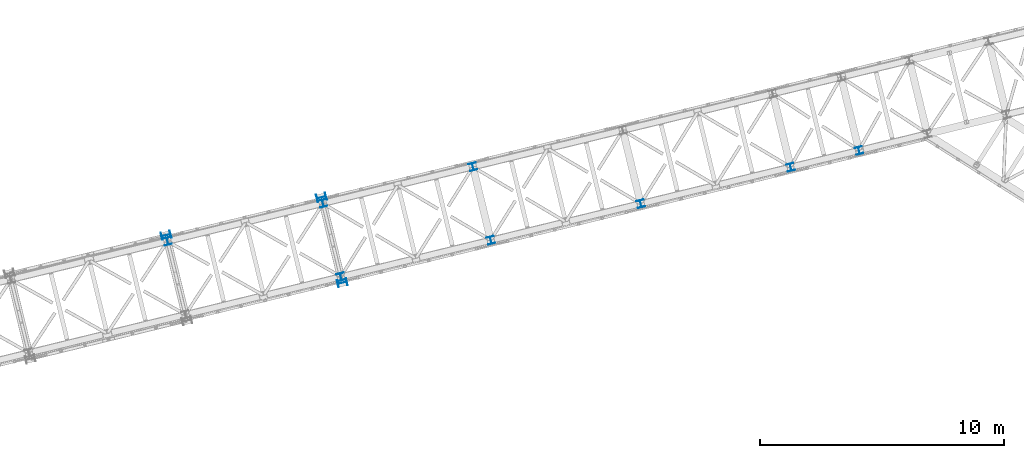
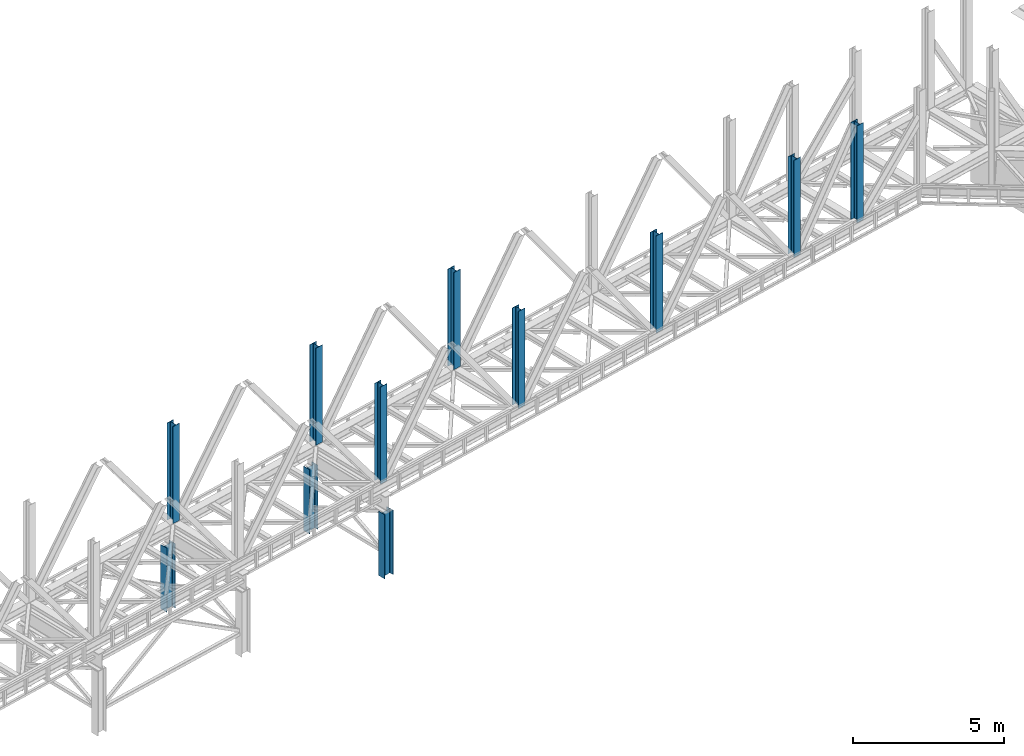
# One storey, part 2 of 93: 11 columns.
"""IFC4 building model written with IfcOpenShell, lengths in millimetres."""

import ifcopenshell
import ifcopenshell.guid

model = None  # the IFC model being written
_history = None  # IfcOwnerHistory: only IFC2X3 demands one
_inside = {}  # id of a spatial element -> (the spatial element, [elements in it])
_under = {}  # id of a project, library or spatial element -> (it, [spatial elements below it])
_declared = {}  # id of a project -> (the project, [libraries it declares])
_typed = {}  # id of a type object -> (the type object, [elements of that type])
_made_of = {}  # id of a material, layer set ... -> (it, [elements and type objects made of it])


def new_model(schema):
    """Start an empty IFC model of exactly this schema.

    Asked for "IFC4X3", IfcOpenShell would pick the latest addendum, in which some entities
    have other attributes; the version numbers below select the first issue.
    IFC2X3 requires an IfcOwnerHistory on every rooted entity: one is made here for all.
    """
    global model, _history
    if schema == "IFC4X3":
        model = ifcopenshell.file(schema_version=(4, 3, 0, 0))
    else:
        model = ifcopenshell.file(schema=schema)
    _inside.clear()
    _under.clear()
    _declared.clear()
    _typed.clear()
    _made_of.clear()
    _history = None
    if model.schema == "IFC2X3":
        org = make("IfcOrganization", Name="unknown")
        user = make(
            "IfcPersonAndOrganization",
            ThePerson=make("IfcPerson", FamilyName="unknown"),
            TheOrganization=org,
        )
        app = make(
            "IfcApplication",
            ApplicationDeveloper=org,
            Version="unknown",
            ApplicationFullName="unknown",
            ApplicationIdentifier="unknown",
        )
        _history = make(
            "IfcOwnerHistory",
            OwningUser=user,
            OwningApplication=app,
            ChangeAction="ADDED",
            CreationDate=0,
        )
    return model


def make(cls, **values):
    """One entity of the class cls with the attributes given. An attribute that is None is left unset."""
    return model.create_entity(
        cls, **{name: value for name, value in values.items() if value is not None}
    )


def entity(cls, *values):
    """Any entity or typed value of the class cls, its attributes in the order of the schema. None: left unset."""
    e = model.create_entity(cls)
    for i, value in enumerate(values):
        if value is not None:
            e[i] = value
    return e


def rooted(cls, **values):
    """An entity with a GlobalId (a new one), such as an element, a storey or a relation."""
    return make(cls, GlobalId=ifcopenshell.guid.new(), OwnerHistory=_history, **values)


def si_unit(unit_type, name, prefix=None):
    """IfcSIUnit, for example si_unit("LENGTHUNIT", "METRE", prefix="MILLI")."""
    return make("IfcSIUnit", UnitType=unit_type, Prefix=prefix, Name=name)


def converted_unit(unit_type, name, factor, base, dimensions=None, offset=None):
    """IfcConversionBasedUnit, such as the inch: factor (a typed value) times the base unit."""
    return make(
        "IfcConversionBasedUnit"
        if offset is None
        else "IfcConversionBasedUnitWithOffset",
        ConversionOffset=offset,
        Dimensions=None
        if dimensions is None
        else entity("IfcDimensionalExponents", *dimensions),
        UnitType=unit_type,
        Name=name,
        ConversionFactor=make(
            "IfcMeasureWithUnit", ValueComponent=factor, UnitComponent=base
        ),
    )


def derived_unit(unit_type, elements):
    """IfcDerivedUnit: a product of units, each with its exponent."""
    return make(
        "IfcDerivedUnit",
        Elements=[
            make("IfcDerivedUnitElement", Unit=unit, Exponent=power)
            for unit, power in elements
        ],
        UnitType=unit_type,
    )


def assignment(units):
    """IfcUnitAssignment: the units of a project."""
    return None if units is None else make("IfcUnitAssignment", Units=units)


def point(xyz):
    """IfcCartesianPoint."""
    return None if xyz is None else make("IfcCartesianPoint", Coordinates=xyz)


def direction(xyz):
    """IfcDirection."""
    return None if xyz is None else make("IfcDirection", DirectionRatios=xyz)


def frame(location, z_axis=None, x_axis=None):
    """IfcAxis2Placement3D, a coordinate frame: its origin and axes. An axis left out is left unset."""
    return make(
        "IfcAxis2Placement3D",
        Location=point(location),
        Axis=direction(z_axis),
        RefDirection=direction(x_axis),
    )


def origin():
    """The frame at (0, 0, 0) with its axes left unset."""
    return frame((0.0, 0.0, 0.0))


def place(relative_to, where):
    """IfcLocalPlacement: puts the frame where relative to a parent placement (None: the world)."""
    return make(
        "IfcLocalPlacement", PlacementRelTo=relative_to, RelativePlacement=where
    )


def context(
    kind, dimensions, precision=None, world=None, true_north=None, identifier=None
):
    """IfcGeometricRepresentationContext, for example the 3D "Model" context."""
    return make(
        "IfcGeometricRepresentationContext",
        ContextIdentifier=identifier,
        ContextType=kind,
        CoordinateSpaceDimension=dimensions,
        Precision=precision,
        WorldCoordinateSystem=world,
        TrueNorth=true_north,
    )


def subcontext(parent, identifier, kind, view, scale=None):
    """IfcGeometricRepresentationSubContext, for example "Body" below "Model"."""
    return make(
        "IfcGeometricRepresentationSubContext",
        ContextIdentifier=identifier,
        ContextType=kind,
        ParentContext=parent,
        TargetScale=scale,
        TargetView=view,
    )


def project(units=None, contexts=None):
    """IfcProject with its units and contexts."""
    return rooted(
        "IfcProject",
        Name="project",
        RepresentationContexts=contexts,
        UnitsInContext=assignment(units),
    )


def spatial(cls, under=None, at=None, **own):
    """A site, building, storey or space (cls), placed at a placement, below another one or the project."""
    s = rooted(cls, ObjectPlacement=at, **own)
    if under is not None:
        _under.setdefault(under.id(), (under, []))[1].append(s)
    return s


def point_list(points):
    """IfcCartesianPointList2D or 3D."""
    cls = (
        "IfcCartesianPointList2D" if len(points[0]) == 2 else "IfcCartesianPointList3D"
    )
    return make(cls, CoordList=points)


def indexed_curve(points, segments=None, self_intersect=None):
    """IfcIndexedPolyCurve: lines and arcs through numbered points (the first is 1)."""
    return make(
        "IfcIndexedPolyCurve",
        Points=point_list(points),
        Segments=segments,
        SelfIntersect=self_intersect,
    )


def outline(outer, holes=None, kind="AREA"):
    """IfcArbitraryClosedProfileDef: a profile drawn as a closed curve; with holes, ...WithVoids."""
    if holes is None:
        return make("IfcArbitraryClosedProfileDef", ProfileType=kind, OuterCurve=outer)
    return make(
        "IfcArbitraryProfileDefWithVoids",
        ProfileType=kind,
        OuterCurve=outer,
        InnerCurves=holes,
    )


def extrude(swept, where, along, depth):
    """IfcExtrudedAreaSolid: the profile swept, set in the frame where, extruded along a direction by depth."""
    return make(
        "IfcExtrudedAreaSolid",
        SweptArea=swept,
        Position=where,
        ExtrudedDirection=direction(along),
        Depth=depth,
    )


def shape(context_of_items, identifier, shape_type, items):
    """IfcShapeRepresentation: the items that make up one representation, for example the "Body"."""
    return make(
        "IfcShapeRepresentation",
        ContextOfItems=context_of_items,
        RepresentationIdentifier=identifier,
        RepresentationType=shape_type,
        Items=items,
    )


def made_of(thing, what):
    """Note that an element or type object is made of a material, layer set ...; save() writes the relation."""
    if what is not None:
        _made_of.setdefault(what.id(), (what, []))[1].append(thing)
    return thing


def type_object(cls, material=None, **own):
    """A type object (cls), such as IfcWallType, which elements share."""
    return made_of(rooted(cls, **own), material)


def element(
    cls,
    number,
    at=None,
    inside=None,
    cuts=None,
    type_object=None,
    material=None,
    context=None,
    identifier="Body",
    shape_type=None,
    held_by="IfcProductDefinitionShape",
    body=None,
    shapes=None,
    **own,
):
    """One element of the class cls, such as IfcWall. Its Tag is "e" and its number.

    at: its placement. inside: the storey or other place that contains it. cuts: it is an
    opening in that element (IfcRelVoidsElement). A single representation is given by context,
    identifier, shape_type and body (its items); several are given by shapes. held_by: the class
    of the entity that holds the representations. save() writes the other relations.
    """
    e = rooted(cls, Tag="e%d" % number, ObjectPlacement=at, **own)
    if body is not None:
        shapes = [shape(context, identifier, shape_type, body)]
    if shapes is not None:
        e.Representation = make(held_by, Representations=shapes)
    if inside is not None:
        _inside.setdefault(inside.id(), (inside, []))[1].append(e)
    if cuts is not None:
        rooted(
            "IfcRelVoidsElement", RelatingBuildingElement=cuts, RelatedOpeningElement=e
        )
    if type_object is not None:
        _typed.setdefault(type_object.id(), (type_object, []))[1].append(e)
    return made_of(e, material)


def aggregate(whole, parts):
    """IfcRelAggregates: a whole, such as a stair, and the parts it consists of."""
    return rooted("IfcRelAggregates", RelatingObject=whole, RelatedObjects=parts)


def save(model, path):
    """Write the relations noted so far, then the file.

    IfcRelAggregates (storeys below a building ...), IfcRelContainedInSpatialStructure (elements
    in a storey), IfcRelDefinesByType, IfcRelAssociatesMaterial and IfcRelDeclares: one each for
    every whole, place, type object, material and project.
    """
    for whole, parts in _under.values():
        aggregate(whole, parts)
    for where, things in _inside.values():
        rooted(
            "IfcRelContainedInSpatialStructure",
            RelatedElements=things,
            RelatingStructure=where,
        )
    for kind, things in _typed.values():
        rooted("IfcRelDefinesByType", RelatedObjects=things, RelatingType=kind)
    for what, things in _made_of.values():
        rooted("IfcRelAssociatesMaterial", RelatedObjects=things, RelatingMaterial=what)
    for by, libraries in _declared.values():
        rooted("IfcRelDeclares", RelatingContext=by, RelatedDefinitions=libraries)
    model.write(path)


model = new_model("IFC4")

# Units and contexts
model_context = context("Model", 3, precision=0.01, world=origin(), true_north=direction((6.12303176911189e-17, 1.0)))
plan_context = context("Plan", 3, precision=0.01, world=origin(), true_north=direction((6.12303176911189e-17, 1.0)))
body_context = subcontext(model_context, "Body", "Model", "MODEL_VIEW")
ifc_project = project(units=[si_unit("LENGTHUNIT", "METRE", prefix="MILLI"), si_unit("AREAUNIT", "SQUARE_METRE"), si_unit("VOLUMEUNIT", "CUBIC_METRE"), converted_unit("PLANEANGLEUNIT", "DEGREE", entity("IfcRatioMeasure", 0.0174532925199433), si_unit("PLANEANGLEUNIT", "RADIAN"), dimensions=[0, 0, 0, 0, 0, 0, 0]), si_unit("MASSUNIT", "GRAM", prefix="KILO"), derived_unit("MASSDENSITYUNIT", [(si_unit("MASSUNIT", "GRAM", prefix="KILO"), 1), (si_unit("LENGTHUNIT", "METRE"), -3)]), derived_unit("MOMENTOFINERTIAUNIT", [(si_unit("LENGTHUNIT", "METRE"), 4)]), si_unit("TIMEUNIT", "SECOND"), si_unit("FREQUENCYUNIT", "HERTZ"), si_unit("THERMODYNAMICTEMPERATUREUNIT", "DEGREE_CELSIUS"), derived_unit("THERMALTRANSMITTANCEUNIT", [(si_unit("MASSUNIT", "GRAM", prefix="KILO"), 1), (si_unit("THERMODYNAMICTEMPERATUREUNIT", "KELVIN"), -1), (si_unit("TIMEUNIT", "SECOND"), -3)]), derived_unit("VOLUMETRICFLOWRATEUNIT", [(si_unit("LENGTHUNIT", "METRE"), 3), (si_unit("TIMEUNIT", "SECOND"), -1)]), derived_unit("MASSFLOWRATEUNIT", [(si_unit("MASSUNIT", "GRAM", prefix="KILO"), 1), (si_unit("TIMEUNIT", "SECOND"), -1)]), derived_unit("ROTATIONALFREQUENCYUNIT", [(si_unit("TIMEUNIT", "SECOND"), -1)]), si_unit("ELECTRICCURRENTUNIT", "AMPERE"), si_unit("ELECTRICVOLTAGEUNIT", "VOLT"), si_unit("POWERUNIT", "WATT"), si_unit("FORCEUNIT", "NEWTON", prefix="KILO"), si_unit("ILLUMINANCEUNIT", "LUX"), si_unit("LUMINOUSFLUXUNIT", "LUMEN"), si_unit("LUMINOUSINTENSITYUNIT", "CANDELA"), derived_unit("USERDEFINED", [(si_unit("MASSUNIT", "GRAM", prefix="KILO"), -1), (si_unit("LENGTHUNIT", "METRE"), -2), (si_unit("TIMEUNIT", "SECOND"), 3), (si_unit("LUMINOUSFLUXUNIT", "LUMEN"), 1)]), derived_unit("LINEARVELOCITYUNIT", [(si_unit("LENGTHUNIT", "METRE"), 1), (si_unit("TIMEUNIT", "SECOND"), -1)]), si_unit("PRESSUREUNIT", "PASCAL"), derived_unit("USERDEFINED", [(si_unit("LENGTHUNIT", "METRE"), -2), (si_unit("MASSUNIT", "GRAM", prefix="KILO"), 1), (si_unit("TIMEUNIT", "SECOND"), -2)]), derived_unit("LINEARFORCEUNIT", [(si_unit("MASSUNIT", "GRAM", prefix="KILO"), 1), (si_unit("LENGTHUNIT", "METRE"), 1), (si_unit("TIMEUNIT", "SECOND"), -2), (si_unit("LENGTHUNIT", "METRE"), -1)]), derived_unit("PLANARFORCEUNIT", [(si_unit("MASSUNIT", "GRAM", prefix="KILO"), 1), (si_unit("LENGTHUNIT", "METRE"), 1), (si_unit("TIMEUNIT", "SECOND"), -2), (si_unit("LENGTHUNIT", "METRE"), -2)])], contexts=[model_context, plan_context])

# Site, building, storey
site_placement = place(None, origin())
site = spatial("IfcSite", under=ifc_project, at=site_placement, CompositionType="ELEMENT")
building_placement = place(site_placement, origin())
building = spatial("IfcBuilding", under=site, at=building_placement, CompositionType="ELEMENT")
storey_placement = place(building_placement, frame((0.0, 0.0, 15900.0)))
storey = spatial("IfcBuildingStorey", under=building, at=storey_placement, CompositionType="ELEMENT", Elevation=15900.0)

# Columns
column_type_1 = type_object("IfcColumnType", PredefinedType="COLUMN")
column_1_placement = place(storey_placement, origin())
element("IfcColumn", 1, at=column_1_placement, inside=storey, type_object=column_type_1, ObjectType="Steel Column", PredefinedType="COLUMN", context=body_context, shape_type="SweptSolid", body=[
    extrude(outline(indexed_curve([(-195.999999999997, -150.000000000012), (-179.999999999993, -150.000000000012), (-180.000000000005, -27.7500000000105), (-178.325349715255, -19.3309644879809), (-173.556349186107, -12.1936508139067), (-166.419035512036, -7.42465028476287), (-158.000000000007, -5.75000000001078), (157.999999999993, -5.74999999998623), (166.419035512024, -7.42465028473864), (173.5563491861, -12.19365081388), (178.325349715248, -19.3309644879522), (179.999999999997, -27.7499999999852), (180.000000000005, -149.999999999983), (196.000000000003, -149.999999999984), (195.99999999998, 150.000000000016), (179.999999999985, 150.000000000014), (179.999999999993, 27.7500000000157), (178.325349715242, 19.330964487984), (173.556349186095, 12.1936508139119), (166.419035512023, 7.42465028476595), (157.99999999999, 5.75000000001489), (-158.000000000005, 5.74999999998931), (-166.419035512038, 7.42465028473751), (-173.556349186113, 12.193650813881), (-178.32534971526, 19.3309644879574), (-180.000000000009, 27.7499999999883), (-180.000000000012, 149.999999999987), (-196.000000000016, 149.999999999985), (-195.999999999997, -150.000000000012)], self_intersect=False)), frame((-36585.8993561306, 12131.4680693305, -2.0), z_axis=(0.0, 0.0, 1.0), x_axis=(-0.971552058141491, -0.236826092990264, 0.0)), (0.0, 0.0, 1.0), 2597.00000000003),
])
column_type_2 = type_object("IfcColumnType", PredefinedType="COLUMN")
column_2_placement = place(storey_placement, origin())
element("IfcColumn", 2, at=column_2_placement, inside=storey, type_object=column_type_2, ObjectType="Steel Column", PredefinedType="COLUMN", context=body_context, shape_type="SweptSolid", body=[
    extrude(outline(indexed_curve([(-195.999999999997, -150.000000000014), (-179.999999999994, -150.000000000014), (-180.000000000001, -27.7500000000136), (-178.325349715246, -19.330964487983), (-173.556349186108, -12.1936508139088), (-166.419035512036, -7.42465028476496), (-158.000000000002, -5.7500000000118), (157.999999999997, -5.74999999998937), (166.419035512032, -7.4246502847407), (173.556349186103, -12.1936508138831), (178.325349715247, -19.3309644879543), (179.999999999996, -27.7499999999873), (180.000000000004, -149.999999999985), (196.000000000012, -149.999999999986), (195.999999999988, 150.000000000014), (179.999999999981, 150.000000000015), (179.999999999992, 27.7500000000136), (178.325349715242, 19.3309644879819), (173.556349186103, 12.1936508139098), (166.419035512032, 7.42465028476389), (157.999999999994, 5.75000000001175), (-158.000000000006, 5.74999999998511), (-166.419035512042, 7.42465028473853), (-173.556349186109, 12.1936508138799), (-178.325349715253, 19.3309644879512), (-180.000000000014, 27.7499999999872), (-180.000000000013, 149.999999999985), (-196.000000000021, 149.999999999986), (-195.999999999997, -150.000000000014)], self_intersect=False)), frame((-29369.6541915994, 10185.0929444516, -1.99240972102241), z_axis=(0.0, 0.0, 1.0), x_axis=(-0.971552058141491, -0.236826092990264, 0.0)), (0.0, 0.0, 1.0), 2596.99999999999),
])
column_type_3 = type_object("IfcColumnType", PredefinedType="COLUMN")
column_3_placement = place(storey_placement, origin())
element("IfcColumn", 3, at=column_3_placement, inside=storey, type_object=column_type_3, ObjectType="Steel Column", PredefinedType="COLUMN", context=body_context, shape_type="SweptSolid", body=[
    extrude(outline(indexed_curve([(-195.99999999998, -150.000000000018), (-179.999999999977, -150.000000000018), (-179.999999999988, -27.7500000000167), (-178.325349715238, -19.330964487985), (-173.556349186095, -12.1936508139119), (-166.419035512024, -7.42465028476805), (-157.999999999986, -5.75000000001591), (158.000000000014, -5.74999999999136), (166.419035512041, -7.42465028474274), (173.556349186116, -12.1936508138862), (178.32534971526, -19.3309644879574), (180.000000000009, -27.7499999999904), (180.000000000017, -149.999999999989), (196.00000000002, -149.999999999989), (195.999999999997, 150.000000000012), (179.999999999997, 150.000000000009), (180.000000000005, 27.7500000000105), (178.325349715254, 19.3309644879788), (173.556349186111, 12.1936508139057), (166.41903551204, 7.42465028476185), (158.00000000001, 5.75000000000765), (-157.99999999998, 5.74999999998316), (-166.41903551202, 7.42465028473551), (-173.556349186095, 12.1936508138811), (-178.325349715243, 19.3309644879533), (-179.999999999988, 27.7499999999831), (-179.999999999997, 149.999999999979), (-196.0, 149.999999999981), (-195.99999999998, -150.000000000018)], self_intersect=False)), frame((-30222.2333753039, 13682.6789784172, -2.0), z_axis=(0.0, 0.0, 1.0), x_axis=(-0.971552058141491, -0.236826092990264, 0.0)), (0.0, 0.0, 1.0), 2597.00000000003),
])
column_type_4 = type_object("IfcColumnType", PredefinedType="COLUMN")
column_4_placement = place(storey_placement, origin())
element("IfcColumn", 4, at=column_4_placement, inside=storey, type_object=column_type_4, ObjectType="Steel Column", PredefinedType="COLUMN", context=body_context, shape_type="SweptSolid", body=[
    extrude(outline(indexed_curve([(-150.000000000029, -149.999999999968), (-134.500000000028, -149.999999999968), (-134.500000000003, -22.9999999999673), (-133.129831585205, -16.1116982173917), (-129.227922061358, -10.2720779386086), (-123.388301782571, -6.37016841476942), (-116.499999999999, -4.99999999996918), (116.500000000001, -5.00000000001784), (123.388301782572, -6.37016841481622), (129.227922061356, -10.2720779386569), (133.129831585201, -16.1116982174475), (134.499999999996, -23.0000000000225), (134.499999999971, -150.000000000024), (149.999999999971, -150.000000000028), (150.000000000031, 149.999999999977), (134.50000000003, 149.999999999977), (134.500000000006, 22.9999999999799), (133.129831585206, 16.1116982174049), (129.227922061361, 10.2720779386212), (123.388301782575, 6.37016841477732), (116.500000000001, 4.9999999999776), (-116.5, 5.00000000002205), (-123.388301782573, 6.37016841482094), (-129.227922061356, 10.2720779386658), (-133.129831585201, 16.1116982174564), (-134.499999999999, 23.000000000032), (-134.499999999972, 150.000000000028), (-149.999999999969, 150.000000000036), (-150.000000000029, -149.999999999968)], self_intersect=False)), frame((-29428.8659637863, 10427.9795836433, 3685.0), z_axis=(0.0, 0.0, 1.0), x_axis=(-0.236826092990533, 0.971552058141425, 0.0)), (0.0, 0.0, 1.0), 3931.00000000001),
])
column_type_5 = type_object("IfcColumnType", PredefinedType="COLUMN")
column_5_placement = place(storey_placement, origin())
element("IfcColumn", 5, at=column_5_placement, inside=storey, type_object=column_type_5, ObjectType="Steel Column", PredefinedType="COLUMN", context=body_context, shape_type="SweptSolid", body=[
    extrude(outline(indexed_curve([(-149.999999999989, -150.000000000009), (-134.499999999988, -150.000000000009), (-134.499999999996, -23.0000000000127), (-133.129831585202, -16.111698217441), (-129.227922061358, -10.2720779386521), (-123.388301782571, -6.37016841480712), (-116.499999999999, -5.00000000000502), (116.500000000001, -4.99999999999042), (123.388301782575, -6.37016841478744), (129.227922061359, -10.2720779386307), (133.129831585205, -16.1116982174245), (134.500000000003, -22.9999999999949), (134.500000000013, -149.999999999992), (150.000000000011, -149.999999999991), (149.999999999992, 150.000000000013), (134.499999999991, 150.000000000008), (134.499999999998, 23.0000000000033), (133.129831585202, 16.1116982174321), (129.227922061359, 10.2720779386474), (123.388301782573, 6.37016841480661), (116.500000000002, 5.00000000000871), (-116.499999999999, 4.99999999998991), (-123.388301782572, 6.37016841478693), (-129.227922061357, 10.2720779386302), (-133.129831585205, 16.1116982174156), (-134.500000000002, 22.9999999999902), (-134.50000000001, 149.999999999991), (-150.000000000009, 149.999999999991), (-149.999999999989, -150.000000000009)], self_intersect=False)), frame((-23288.6569563322, 11924.7204913422, 3685.0), z_axis=(0.0, 0.0, 1.0), x_axis=(-0.236826092990269, 0.97155205814149, 0.0)), (0.0, 0.0, 1.0), 3931.00000000001),
])
column_type_6 = type_object("IfcColumnType", PredefinedType="COLUMN")
column_6_placement = place(storey_placement, origin())
element("IfcColumn", 6, at=column_6_placement, inside=storey, type_object=column_type_6, ObjectType="Steel Column", PredefinedType="COLUMN", context=body_context, shape_type="SweptSolid", body=[
    extrude(outline(indexed_curve([(-149.99999999999, -150.000000000013), (-134.499999999989, -150.000000000013), (-134.499999999999, -23.0000000000143), (-133.129831585202, -16.1116982174342), (-129.227922061359, -10.2720779386563), (-123.388301782571, -6.3701684147982), (-116.5, -5.0000000000003), (116.500000000001, -4.9999999999836), (123.388301782571, -6.3701684147822), (129.227922061357, -10.2720779386391), (133.129831585205, -16.1116982174156), (134.5, -22.9999999999965), (134.50000000001, -149.999999999993), (150.000000000011, -149.999999999991), (149.999999999989, 150.000000000009), (134.499999999988, 150.000000000009), (134.499999999998, 23.0000000000101), (133.129831585201, 16.11169821743), (129.227922061358, 10.2720779386432), (123.388301782572, 6.37016841481134), (116.499999999999, 5.00000000001395), (-116.500000000005, 4.99999999999355), (-123.388301782578, 6.37016841479056), (-129.22792206136, 10.2720779386286), (-133.129831585208, 16.1116982174119), (-134.500000000004, 22.9999999999997), (-134.500000000012, 149.999999999994), (-150.000000000012, 149.999999999987), (-149.99999999999, -150.000000000013)], self_intersect=False)), frame((-17148.4479488781, 13421.4613990411, 3685.0), z_axis=(0.0, 0.0, 1.0), x_axis=(-0.236826092990269, 0.97155205814149, 0.0)), (0.0, 0.0, 1.0), 3931.00000000001),
])
column_type_7 = type_object("IfcColumnType", PredefinedType="COLUMN")
column_7_placement = place(storey_placement, origin())
element("IfcColumn", 7, at=column_7_placement, inside=storey, type_object=column_type_7, ObjectType="Steel Column", PredefinedType="COLUMN", context=body_context, shape_type="SweptSolid", body=[
    extrude(outline(indexed_curve([(-149.999999999989, -150.000000000011), (-134.499999999989, -150.000000000011), (-134.499999999998, -23.0000000000033), (-133.129831585202, -16.111698217441), (-129.227922061358, -10.2720779386542), (-123.388301782572, -6.37016841480451), (-116.5, -5.00000000000713), (116.500000000001, -4.99999999999042), (123.388301782572, -6.37016841478903), (129.227922061358, -10.272077938637), (133.129831585205, -16.1116982174224), (134.500000000003, -22.999999999986), (134.50000000001, -149.999999999991), (150.000000000011, -149.999999999989), (149.999999999989, 150.000000000011), (134.499999999989, 150.000000000011), (134.499999999998, 23.0000000000122), (133.129831585202, 16.111698217441), (129.227922061356, 10.2720779386547), (123.38830178257, 6.37016841480503), (116.5, 5.00000000000713), (-116.500000000003, 4.99999999998411), (-123.388301782573, 6.37016841478482), (-129.227922061361, 10.2720779386312), (-133.129831585207, 16.1116982174229), (-134.500000000004, 22.9999999999907), (-134.500000000014, 149.999999999988), (-150.000000000011, 149.999999999989), (-149.999999999989, -150.000000000011)], self_intersect=False)), frame((-11008.238941424, 14918.20230674, 3685.0), z_axis=(0.0, 0.0, 1.0), x_axis=(-0.236826092990269, 0.97155205814149, 0.0)), (0.0, 0.0, 1.0), 3931.00000000001),
])
column_type_8 = type_object("IfcColumnType", PredefinedType="COLUMN")
column_8_placement = place(storey_placement, origin())
element("IfcColumn", 8, at=column_8_placement, inside=storey, type_object=column_type_8, ObjectType="Steel Column", PredefinedType="COLUMN", context=body_context, shape_type="SweptSolid", body=[
    extrude(outline(indexed_curve([(-150.000000000006, -149.999999999994), (-134.500000000008, -149.999999999994), (-134.500000000003, -22.9999999999892), (-133.129831585205, -16.111698217426), (-129.227922061361, -10.2720779386396), (-123.388301782575, -6.37016841479049), (-116.500000000002, -4.9999999999938), (116.499999999999, -5.00000000000062), (123.38830178257, -6.37016841479887), (129.227922061355, -10.2720779386485), (133.129831585202, -16.1116982174343), (134.499999999999, -22.999999999997), (134.499999999993, -150.000000000003), (149.999999999994, -150.000000000004), (150.000000000002, 149.999999999998), (134.500000000002, 149.999999999998), (134.499999999999, 22.9999999999923), (133.129831585202, 16.1116982174291), (129.227922061355, 10.2720779386353), (123.388301782569, 6.37016841480306), (116.499999999998, 5.00000000000586), (-116.500000000006, 4.99999999999901), (-123.388301782581, 6.37016841479828), (-129.227922061362, 10.2720779386369), (-133.12983158521, 16.1116982174374), (-134.500000000003, 22.999999999998), (-134.5, 150.000000000003), (-149.999999999998, 150.000000000007), (-150.000000000006, -149.999999999994)], self_intersect=False)), frame((-8210.16901397661, 15600.2614545522, 3685.0), z_axis=(0.0, 0.0, 1.0), x_axis=(-0.236826092990367, 0.971552058141466, 0.0)), (0.0, 0.0, 1.0), 3931.00000000001),
])
column_type_9 = type_object("IfcColumnType", PredefinedType="COLUMN")
column_9_placement = place(storey_placement, origin())
element("IfcColumn", 9, at=column_9_placement, inside=storey, type_object=column_type_9, ObjectType="Steel Column", PredefinedType="COLUMN", context=body_context, shape_type="SweptSolid", body=[
    extrude(outline(indexed_curve([(-149.999999999993, -149.999999999999), (-134.499999999993, -149.999999999999), (-134.500000000002, -22.999999999998), (-133.129831585206, -16.1116982174221), (-129.227922061361, -10.2720779386379), (-123.388301782575, -6.37016841479717), (-116.500000000001, -4.99999999999558), (116.499999999997, -4.99999999998047), (123.388301782568, -6.37016841477697), (129.227922061356, -10.2720779386165), (133.1298315852, -16.1116982174056), (134.499999999999, -22.9999999999808), (134.500000000008, -149.999999999982), (150.000000000008, -149.999999999982), (149.999999999987, 150.000000000023), (134.499999999986, 150.000000000018), (134.499999999996, 23.0000000000216), (133.129831585199, 16.1116982174462), (129.227922061353, 10.272077938662), (123.388301782568, 6.37016841481657), (116.499999999998, 5.00000000001867), (-116.500000000001, 4.99999999999935), (-123.388301782572, 6.37016841479585), (-129.227922061361, 10.2720779386401), (-133.129831585206, 16.1116982174292), (-134.500000000005, 23.0000000000044), (-134.500000000013, 150.000000000001), (-150.000000000013, 150.000000000001), (-149.999999999993, -149.999999999999)], self_intersect=False)), frame((-30163.0268520564, 13439.7909638818, 3685.0), z_axis=(0.0, 0.0, 1.0), x_axis=(-0.236826092990269, 0.97155205814149, 0.0)), (0.0, 0.0, 1.0), 3931.00000000001),
])
column_type_10 = type_object("IfcColumnType", PredefinedType="COLUMN")
column_10_placement = place(storey_placement, origin())
element("IfcColumn", 10, at=column_10_placement, inside=storey, type_object=column_type_10, ObjectType="Steel Column", PredefinedType="COLUMN", context=body_context, shape_type="SweptSolid", body=[
    extrude(outline(indexed_curve([(-149.999999999984, -150.000000000001), (-134.499999999984, -150.000000000001), (-134.499999999993, -23.0000000000001), (-133.129831585198, -16.1116982174331), (-129.227922061352, -10.2720779386489), (-123.388301782564, -6.37016841479973), (-116.499999999994, -5.00000000000184), (116.500000000006, -4.99999999998724), (123.388301782578, -6.37016841478374), (129.227922061365, -10.2720779386275), (133.12983158521, -16.1116982174124), (134.500000000008, -22.9999999999828), (134.500000000017, -149.999999999984), (150.000000000017, -149.999999999984), (149.999999999996, 150.000000000021), (134.499999999995, 150.000000000016), (134.500000000004, 23.0000000000154), (133.129831585207, 16.1116982174442), (129.227922061363, 10.2720779386642), (123.388301782577, 6.37016841481452), (116.500000000006, 5.00000000001662), (-116.499999999996, 5.00000000000253), (-123.388301782565, 6.37016841479852), (-129.227922061355, 10.2720779386475), (-133.129831585197, 16.1116982174272), (-134.499999999996, 23.0000000000023), (-134.500000000004, 149.999999999999), (-150.000000000004, 149.999999999999), (-149.999999999984, -150.000000000001)], self_intersect=False)), frame((-24022.8178446023, 14936.5318715807, 3685.0), z_axis=(0.0, 0.0, 1.0), x_axis=(-0.236826092990269, 0.97155205814149, 0.0)), (0.0, 0.0, 1.0), 3931.00000000001),
])
column_type_11 = type_object("IfcColumnType", PredefinedType="COLUMN")
column_11_placement = place(storey_placement, origin())
element("IfcColumn", 11, at=column_11_placement, inside=storey, type_object=column_type_11, ObjectType="Steel Column", PredefinedType="COLUMN", context=body_context, shape_type="SweptSolid", body=[
    extrude(outline(indexed_curve([(-149.999999999989, -150.000000000009), (-134.499999999988, -150.000000000009), (-134.499999999997, -23.000000000008), (-133.129831585201, -16.1116982174368), (-129.227922061355, -10.2720779386526), (-123.388301782571, -6.37016841480713), (-116.499999999997, -5.00000000000553), (116.500000000001, -4.99999999999042), (123.388301782572, -6.37016841478692), (129.227922061361, -10.2720779386312), (133.129831585206, -16.1116982174203), (134.500000000004, -22.9999999999907), (134.500000000013, -149.999999999992), (150.000000000013, -149.999999999992), (149.999999999992, 150.000000000013), (134.499999999991, 150.000000000008), (134.499999999999, 23.0000000000075), (133.129831585203, 16.1116982174363), (129.22792206136, 10.2720779386516), (123.388301782573, 6.37016841480661), (116.500000000002, 5.00000000000872), (-116.499999999998, 4.99999999999412), (-123.388301782569, 6.37016841479062), (-129.227922061358, 10.2720779386349), (-133.129831585203, 16.1116982174151), (-134.500000000001, 22.9999999999944), (-134.500000000007, 149.999999999995), (-150.000000000009, 149.999999999991), (-149.999999999989, -150.000000000009)], self_intersect=False)), frame((-36526.6875618876, 11888.581339656, 3685.0), z_axis=(0.0, 0.0, 1.0), x_axis=(-0.236826092990269, 0.97155205814149, 0.0)), (0.0, 0.0, 1.0), 3931.00000000001),
])

save(model, "model.ifc")
